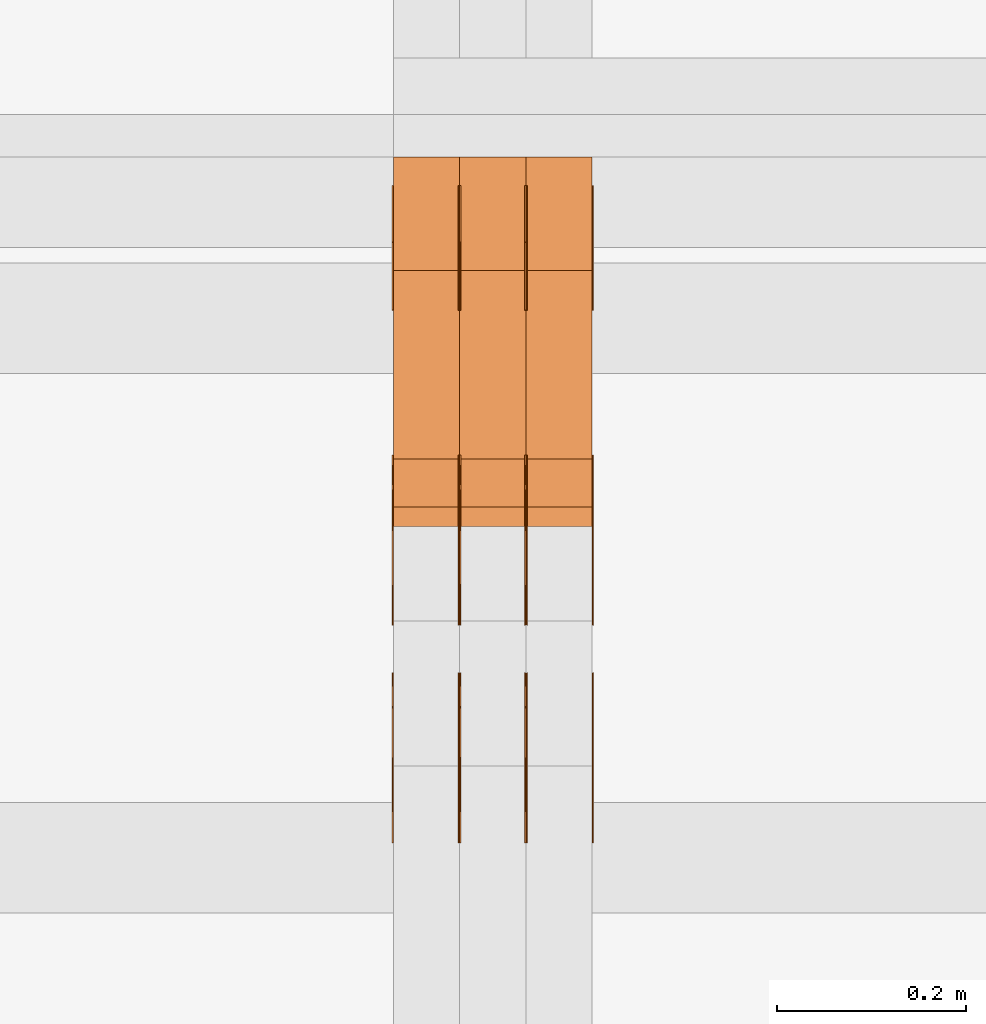
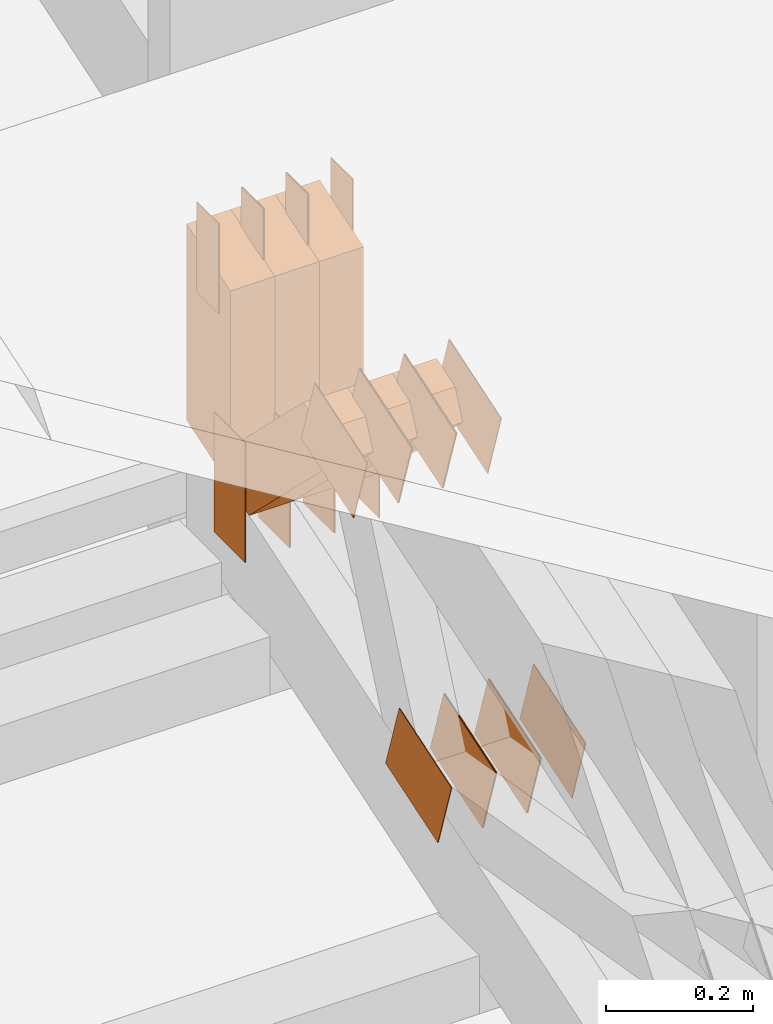
# One storey, part 146 of 385: 30 proxies.
"""IFC2X3 building model written with IfcOpenShell, lengths in millimetres."""

from ifc_helpers import new_model, entity, si_unit, converted_unit, derived_unit, direction, frame, frame_2d, origin, origin_2d_with_axis, place, context, subcontext, project, spatial, polyline, rectangle, outline, extrude, source, transform, mapped, material, type_object, type_shapes, element, save


model = new_model("IFC2X3")

# Units and contexts
model_context = context("Model", 3, precision=0.01, world=origin(), true_north=direction((6.12303176911189e-17, 1.0)))
body_context = subcontext(model_context, "Body", "Model", "MODEL_VIEW")
ifc_project = project(units=[si_unit("LENGTHUNIT", "METRE", prefix="MILLI"), si_unit("AREAUNIT", "SQUARE_METRE"), si_unit("VOLUMEUNIT", "CUBIC_METRE"), converted_unit("PLANEANGLEUNIT", "DEGREE", entity("IfcRatioMeasure", 0.0174532925199433), si_unit("PLANEANGLEUNIT", "RADIAN"), dimensions=[0, 0, 0, 0, 0, 0, 0]), si_unit("MASSUNIT", "GRAM", prefix="KILO"), derived_unit("MASSDENSITYUNIT", [(si_unit("MASSUNIT", "GRAM", prefix="KILO"), 1), (si_unit("LENGTHUNIT", "METRE"), -3)]), si_unit("TIMEUNIT", "SECOND"), si_unit("FREQUENCYUNIT", "HERTZ"), si_unit("THERMODYNAMICTEMPERATUREUNIT", "DEGREE_CELSIUS"), derived_unit("THERMALTRANSMITTANCEUNIT", [(si_unit("MASSUNIT", "GRAM", prefix="KILO"), 1), (si_unit("THERMODYNAMICTEMPERATUREUNIT", "KELVIN"), -1), (si_unit("TIMEUNIT", "SECOND"), -3)]), derived_unit("VOLUMETRICFLOWRATEUNIT", [(si_unit("LENGTHUNIT", "METRE"), 3), (si_unit("TIMEUNIT", "SECOND"), -1)]), si_unit("ELECTRICCURRENTUNIT", "AMPERE"), si_unit("ELECTRICVOLTAGEUNIT", "VOLT"), si_unit("POWERUNIT", "WATT"), si_unit("FORCEUNIT", "NEWTON", prefix="KILO"), si_unit("ILLUMINANCEUNIT", "LUX"), si_unit("LUMINOUSFLUXUNIT", "LUMEN"), si_unit("LUMINOUSINTENSITYUNIT", "CANDELA"), derived_unit("USERDEFINED", [(si_unit("MASSUNIT", "GRAM", prefix="KILO"), -1), (si_unit("LENGTHUNIT", "METRE"), -2), (si_unit("TIMEUNIT", "SECOND"), 3), (si_unit("LUMINOUSFLUXUNIT", "LUMEN"), 1)]), derived_unit("LINEARVELOCITYUNIT", [(si_unit("LENGTHUNIT", "METRE"), 1), (si_unit("TIMEUNIT", "SECOND"), -1)]), si_unit("PRESSUREUNIT", "PASCAL"), derived_unit("USERDEFINED", [(si_unit("LENGTHUNIT", "METRE"), -2), (si_unit("MASSUNIT", "GRAM", prefix="KILO"), 1), (si_unit("TIMEUNIT", "SECOND"), -2)])], contexts=[model_context])

# Site, building, storey
site_placement = place(None, origin())
site = spatial("IfcSite", under=ifc_project, at=site_placement, CompositionType="ELEMENT")
building_placement = place(site_placement, origin())
building = spatial("IfcBuilding", under=site, at=building_placement, CompositionType="ELEMENT")
storey_placement = place(building_placement, origin())
storey = spatial("IfcBuildingStorey", under=building, at=storey_placement, Name="Default", CompositionType="ELEMENT", Elevation=0.0)

# Proxies
ifc_material_1 = material(Name="IfcSurfaceStyle #278004")
building_element_proxy_type_1 = type_object("IfcBuildingElementProxyType", PredefinedType="NOTDEFINED", material=ifc_material_1)
shared_shape_1 = source(origin(), body_context, "Body", "SweptSolid", [
    extrude(rectangle(XDim=200.0, YDim=84.0, at=frame_2d((0.0, -7.105427357601e-15), x_axis=(1.0, 0.0))), frame((100.0, 42.0, 0.0), z_axis=(0.0, 0.0, 1.0), x_axis=(-1.0, 0.0, 0.0)), (0.0, 0.0, 1.0), 1.3),
])
type_shapes(building_element_proxy_type_1, [shared_shape_1])
proxy_1_placement = place(building_placement, frame((21386.3, 13702.0, 3651.4150390625), z_axis=(-1.0, 0.0, 0.0), x_axis=(0.0, 0.0, -1.0)))
element("IfcBuildingElementProxy", 1, at=proxy_1_placement, inside=storey, type_object=building_element_proxy_type_1, material=ifc_material_1, context=body_context, shape_type="MappedRepresentation", body=[
    mapped(shared_shape_1, transform((0.0, 0.0, 0.0), scale=1.0)),
])
ifc_material_2 = material(Name="IfcSurfaceStyle #277947")
building_element_proxy_type_2 = type_object("IfcBuildingElementProxyType", PredefinedType="NOTDEFINED", material=ifc_material_2)
shared_shape_2 = source(origin(), body_context, "Body", "SweptSolid", [
    extrude(rectangle(XDim=200.0, YDim=84.0, at=frame_2d((0.0, -7.105427357601e-15), x_axis=(1.0, 0.0))), frame((100.0, 42.0, 0.0), z_axis=(0.0, 0.0, 1.0), x_axis=(-1.0, 0.0, 0.0)), (0.0, 0.0, 1.0), 1.3),
])
type_shapes(building_element_proxy_type_2, [shared_shape_2])
proxy_2_placement = place(building_placement, frame((21315.0, 13702.0, 3651.4150390625), z_axis=(-1.0, 0.0, 0.0), x_axis=(0.0, 0.0, -1.0)))
element("IfcBuildingElementProxy", 2, at=proxy_2_placement, inside=storey, type_object=building_element_proxy_type_2, material=ifc_material_2, context=body_context, shape_type="MappedRepresentation", body=[
    mapped(shared_shape_2, transform((0.0, 0.0, 0.0), scale=1.0)),
])
ifc_material_3 = material(Name="IfcSurfaceStyle #277890")
building_element_proxy_type_3 = type_object("IfcBuildingElementProxyType", PredefinedType="NOTDEFINED", material=ifc_material_3)
shared_shape_3 = source(origin(), body_context, "Body", "SweptSolid", [
    extrude(rectangle(XDim=200.0, YDim=84.0, at=frame_2d((0.0, -7.105427357601e-15), x_axis=(1.0, 0.0))), frame((100.0, 42.0, 0.0), z_axis=(0.0, 0.0, 1.0), x_axis=(-1.0, 0.0, 0.0)), (0.0, 0.0, 1.0), 1.3),
])
type_shapes(building_element_proxy_type_3, [shared_shape_3])
proxy_3_placement = place(building_placement, frame((21316.3, 13702.0, 3651.4150390625), z_axis=(-1.0, 0.0, 0.0), x_axis=(0.0, 0.0, -1.0)))
element("IfcBuildingElementProxy", 3, at=proxy_3_placement, inside=storey, type_object=building_element_proxy_type_3, material=ifc_material_3, context=body_context, shape_type="MappedRepresentation", body=[
    mapped(shared_shape_3, transform((0.0, 0.0, 0.0), scale=1.0)),
])
ifc_material_4 = material(Name="IfcSurfaceStyle #277833")
building_element_proxy_type_4 = type_object("IfcBuildingElementProxyType", PredefinedType="NOTDEFINED", material=ifc_material_4)
shared_shape_4 = source(origin(), body_context, "Body", "SweptSolid", [
    extrude(rectangle(XDim=200.0, YDim=84.0, at=frame_2d((0.0, -7.105427357601e-15), x_axis=(1.0, 0.0))), frame((100.0, 42.0, 0.0), z_axis=(0.0, 0.0, 1.0), x_axis=(-1.0, 0.0, 0.0)), (0.0, 0.0, 1.0), 1.29999999999998),
])
type_shapes(building_element_proxy_type_4, [shared_shape_4])
proxy_4_placement = place(building_placement, frame((21245.0, 13702.0, 3651.4150390625), z_axis=(-1.0, 0.0, 0.0), x_axis=(0.0, 0.0, -1.0)))
element("IfcBuildingElementProxy", 4, at=proxy_4_placement, inside=storey, type_object=building_element_proxy_type_4, material=ifc_material_4, context=body_context, shape_type="MappedRepresentation", body=[
    mapped(shared_shape_4, transform((0.0, 0.0, 0.0), scale=1.0)),
])
ifc_material_5 = material(Name="IfcSurfaceStyle #277776")
building_element_proxy_type_5 = type_object("IfcBuildingElementProxyType", PredefinedType="NOTDEFINED", material=ifc_material_5)
shared_shape_5 = source(origin(), body_context, "Body", "SweptSolid", [
    extrude(rectangle(XDim=200.0, YDim=84.0, at=frame_2d((0.0, -7.105427357601e-15), x_axis=(1.0, 0.0))), frame((100.0, 42.0, 0.0), z_axis=(0.0, 0.0, 1.0), x_axis=(-1.0, 0.0, 0.0)), (0.0, 0.0, 1.0), 1.29999999999998),
])
type_shapes(building_element_proxy_type_5, [shared_shape_5])
proxy_5_placement = place(building_placement, frame((21246.3, 13702.0, 3651.4150390625), z_axis=(-1.0, 0.0, 0.0), x_axis=(0.0, 0.0, -1.0)))
element("IfcBuildingElementProxy", 5, at=proxy_5_placement, inside=storey, type_object=building_element_proxy_type_5, material=ifc_material_5, context=body_context, shape_type="MappedRepresentation", body=[
    mapped(shared_shape_5, transform((0.0, 0.0, 0.0), scale=1.0)),
])
ifc_material_6 = material(Name="IfcSurfaceStyle #277719")
building_element_proxy_type_6 = type_object("IfcBuildingElementProxyType", PredefinedType="NOTDEFINED", material=ifc_material_6)
shared_shape_6 = source(origin(), body_context, "Body", "SweptSolid", [
    extrude(rectangle(XDim=200.0, YDim=84.0, at=frame_2d((0.0, -7.105427357601e-15), x_axis=(1.0, 0.0))), frame((100.0, 42.0, 0.0), z_axis=(0.0, 0.0, 1.0), x_axis=(-1.0, 0.0, 0.0)), (0.0, 0.0, 1.0), 1.29999999999999),
])
type_shapes(building_element_proxy_type_6, [shared_shape_6])
proxy_6_placement = place(building_placement, frame((21175.0, 13702.0, 3651.4150390625), z_axis=(-1.0, 0.0, 0.0), x_axis=(0.0, 0.0, -1.0)))
element("IfcBuildingElementProxy", 6, at=proxy_6_placement, inside=storey, type_object=building_element_proxy_type_6, material=ifc_material_6, context=body_context, shape_type="MappedRepresentation", body=[
    mapped(shared_shape_6, transform((0.0, 0.0, 0.0), scale=1.0)),
])
ifc_material_7 = material(Name="IfcSurfaceStyle #277662")
building_element_proxy_type_7 = type_object("IfcBuildingElementProxyType", PredefinedType="NOTDEFINED", material=ifc_material_7)
shared_shape_7 = source(origin(), body_context, "Body", "SweptSolid", [
    extrude(outline(polyline([(-75.0003398116828, -59.9998507501386), (75.0003249421766, -59.9998507501386), (75.0003398116837, 59.9998507501387), (-75.0003249421775, 59.9998507501387), (-75.0003398116828, -59.9998507501386)])), frame((75.0003398116837, 60.0000773549637, 0.0), z_axis=(0.0, 0.0, 1.0), x_axis=(-1.0, 0.0, 0.0)), (0.0, 0.0, 1.0), 1.3),
])
type_shapes(building_element_proxy_type_7, [shared_shape_7])
proxy_7_placement = place(building_placement, frame((21386.3, 13054.73046875, 3417.8388671875), z_axis=(-1.0, 0.0, 0.0), x_axis=(0.0, 0.951056516295124, 0.309016994375039)))
element("IfcBuildingElementProxy", 7, at=proxy_7_placement, inside=storey, type_object=building_element_proxy_type_7, material=ifc_material_7, context=body_context, shape_type="MappedRepresentation", body=[
    mapped(shared_shape_7, transform((0.0, 0.0, 0.0), scale=1.0)),
])
ifc_material_8 = material(Name="IfcSurfaceStyle #277605")
building_element_proxy_type_8 = type_object("IfcBuildingElementProxyType", PredefinedType="NOTDEFINED", material=ifc_material_8)
shared_shape_8 = source(origin(), body_context, "Body", "SweptSolid", [
    extrude(outline(polyline([(-75.0003398116828, -59.9998507501386), (75.0003249421766, -59.9998507501386), (75.0003398116837, 59.9998507501387), (-75.0003249421775, 59.9998507501387), (-75.0003398116828, -59.9998507501386)])), frame((75.0003398116837, 60.0000773549637, 0.0), z_axis=(0.0, 0.0, 1.0), x_axis=(-1.0, 0.0, 0.0)), (0.0, 0.0, 1.0), 1.3),
])
type_shapes(building_element_proxy_type_8, [shared_shape_8])
proxy_8_placement = place(building_placement, frame((21315.0, 13054.73046875, 3417.8388671875), z_axis=(-1.0, 0.0, 0.0), x_axis=(0.0, 0.951056516295124, 0.309016994375039)))
element("IfcBuildingElementProxy", 8, at=proxy_8_placement, inside=storey, type_object=building_element_proxy_type_8, material=ifc_material_8, context=body_context, shape_type="MappedRepresentation", body=[
    mapped(shared_shape_8, transform((0.0, 0.0, 0.0), scale=1.0)),
])
ifc_material_9 = material(Name="IfcSurfaceStyle #277548")
building_element_proxy_type_9 = type_object("IfcBuildingElementProxyType", PredefinedType="NOTDEFINED", material=ifc_material_9)
shared_shape_9 = source(origin(), body_context, "Body", "SweptSolid", [
    extrude(outline(polyline([(-75.0003398116828, -59.9998507501386), (75.0003249421766, -59.9998507501386), (75.0003398116837, 59.9998507501387), (-75.0003249421775, 59.9998507501387), (-75.0003398116828, -59.9998507501386)])), frame((75.0003398116837, 60.0000773549637, 0.0), z_axis=(0.0, 0.0, 1.0), x_axis=(-1.0, 0.0, 0.0)), (0.0, 0.0, 1.0), 1.3),
])
type_shapes(building_element_proxy_type_9, [shared_shape_9])
proxy_9_placement = place(building_placement, frame((21316.3, 13054.73046875, 3417.8388671875), z_axis=(-1.0, 0.0, 0.0), x_axis=(0.0, 0.951056516295124, 0.309016994375039)))
element("IfcBuildingElementProxy", 9, at=proxy_9_placement, inside=storey, type_object=building_element_proxy_type_9, material=ifc_material_9, context=body_context, shape_type="MappedRepresentation", body=[
    mapped(shared_shape_9, transform((0.0, 0.0, 0.0), scale=1.0)),
])
ifc_material_10 = material(Name="IfcSurfaceStyle #277491")
building_element_proxy_type_10 = type_object("IfcBuildingElementProxyType", PredefinedType="NOTDEFINED", material=ifc_material_10)
shared_shape_10 = source(origin(), body_context, "Body", "SweptSolid", [
    extrude(outline(polyline([(-75.0003398116828, -59.9998507501386), (75.0003249421766, -59.9998507501386), (75.0003398116837, 59.9998507501387), (-75.0003249421775, 59.9998507501387), (-75.0003398116828, -59.9998507501386)])), frame((75.0003398116837, 60.0000773549637, 0.0), z_axis=(0.0, 0.0, 1.0), x_axis=(-1.0, 0.0, 0.0)), (0.0, 0.0, 1.0), 1.29999999999999),
])
type_shapes(building_element_proxy_type_10, [shared_shape_10])
proxy_10_placement = place(building_placement, frame((21245.0, 13054.73046875, 3417.8388671875), z_axis=(-1.0, 0.0, 0.0), x_axis=(0.0, 0.951056516295124, 0.309016994375039)))
element("IfcBuildingElementProxy", 10, at=proxy_10_placement, inside=storey, type_object=building_element_proxy_type_10, material=ifc_material_10, context=body_context, shape_type="MappedRepresentation", body=[
    mapped(shared_shape_10, transform((0.0, 0.0, 0.0), scale=1.0)),
])
ifc_material_11 = material(Name="IfcSurfaceStyle #277434")
building_element_proxy_type_11 = type_object("IfcBuildingElementProxyType", PredefinedType="NOTDEFINED", material=ifc_material_11)
shared_shape_11 = source(origin(), body_context, "Body", "SweptSolid", [
    extrude(outline(polyline([(-75.0003398116828, -59.9998507501386), (75.0003249421766, -59.9998507501386), (75.0003398116837, 59.9998507501387), (-75.0003249421775, 59.9998507501387), (-75.0003398116828, -59.9998507501386)])), frame((75.0003398116837, 60.0000773549637, 0.0), z_axis=(0.0, 0.0, 1.0), x_axis=(-1.0, 0.0, 0.0)), (0.0, 0.0, 1.0), 1.29999999999999),
])
type_shapes(building_element_proxy_type_11, [shared_shape_11])
proxy_11_placement = place(building_placement, frame((21246.3, 13054.73046875, 3417.8388671875), z_axis=(-1.0, 0.0, 0.0), x_axis=(0.0, 0.951056516295124, 0.309016994375039)))
element("IfcBuildingElementProxy", 11, at=proxy_11_placement, inside=storey, type_object=building_element_proxy_type_11, material=ifc_material_11, context=body_context, shape_type="MappedRepresentation", body=[
    mapped(shared_shape_11, transform((0.0, 0.0, 0.0), scale=1.0)),
])
ifc_material_12 = material(Name="IfcSurfaceStyle #277377")
building_element_proxy_type_12 = type_object("IfcBuildingElementProxyType", PredefinedType="NOTDEFINED", material=ifc_material_12)
shared_shape_12 = source(origin(), body_context, "Body", "SweptSolid", [
    extrude(outline(polyline([(-75.0003398116828, -59.9998507501386), (75.0003249421766, -59.9998507501386), (75.0003398116837, 59.9998507501387), (-75.0003249421775, 59.9998507501387), (-75.0003398116828, -59.9998507501386)])), frame((75.0003398116837, 60.0000773549637, 0.0), z_axis=(0.0, 0.0, 1.0), x_axis=(-1.0, 0.0, 0.0)), (0.0, 0.0, 1.0), 1.29999999999999),
])
type_shapes(building_element_proxy_type_12, [shared_shape_12])
proxy_12_placement = place(building_placement, frame((21175.0, 13054.73046875, 3417.8388671875), z_axis=(-1.0, 0.0, 0.0), x_axis=(0.0, 0.951056516295124, 0.309016994375039)))
element("IfcBuildingElementProxy", 12, at=proxy_12_placement, inside=storey, type_object=building_element_proxy_type_12, material=ifc_material_12, context=body_context, shape_type="MappedRepresentation", body=[
    mapped(shared_shape_12, transform((0.0, 0.0, 0.0), scale=1.0)),
])
ifc_material_13 = material(Name="IfcSurfaceStyle #269796")
building_element_proxy_type_13 = type_object("IfcBuildingElementProxyType", PredefinedType="NOTDEFINED", material=ifc_material_13)
shared_shape_13 = source(origin(), body_context, "Body", "SweptSolid", [
    extrude(outline(polyline([(-74.999875428623, -60.0000016373506), (74.9998605591059, -60.0000016373506), (74.9998754286239, 60.0000016373506), (-74.9998605591068, 60.0000016373506), (-74.999875428623, -60.0000016373506)])), frame((75.0002691827262, 60.0000190504561, 0.0), z_axis=(0.0, 0.0, 1.0), x_axis=(-1.0, 0.0, 0.0)), (0.0, 0.0, 1.0), 1.3),
])
type_shapes(building_element_proxy_type_13, [shared_shape_13])
proxy_13_placement = place(building_placement, frame((21386.3, 13285.0865109705, 3819.37496637467), z_axis=(-1.0, 0.0, 0.0), x_axis=(0.0, 0.951056516295154, 0.309016994374948)))
element("IfcBuildingElementProxy", 13, at=proxy_13_placement, inside=storey, type_object=building_element_proxy_type_13, material=ifc_material_13, context=body_context, shape_type="MappedRepresentation", body=[
    mapped(shared_shape_13, transform((0.0, 0.0, 0.0), scale=1.0)),
])
ifc_material_14 = material(Name="IfcSurfaceStyle #269739")
building_element_proxy_type_14 = type_object("IfcBuildingElementProxyType", PredefinedType="NOTDEFINED", material=ifc_material_14)
shared_shape_14 = source(origin(), body_context, "Body", "SweptSolid", [
    extrude(outline(polyline([(-74.999875428623, -60.0000016373506), (74.9998605591059, -60.0000016373506), (74.9998754286239, 60.0000016373506), (-74.9998605591068, 60.0000016373506), (-74.999875428623, -60.0000016373506)])), frame((75.0002691827262, 60.0000190504561, 0.0), z_axis=(0.0, 0.0, 1.0), x_axis=(-1.0, 0.0, 0.0)), (0.0, 0.0, 1.0), 1.3),
])
type_shapes(building_element_proxy_type_14, [shared_shape_14])
proxy_14_placement = place(building_placement, frame((21315.0, 13285.0865109705, 3819.37496637467), z_axis=(-1.0, 0.0, 0.0), x_axis=(0.0, 0.951056516295154, 0.309016994374948)))
element("IfcBuildingElementProxy", 14, at=proxy_14_placement, inside=storey, type_object=building_element_proxy_type_14, material=ifc_material_14, context=body_context, shape_type="MappedRepresentation", body=[
    mapped(shared_shape_14, transform((0.0, 0.0, 0.0), scale=1.0)),
])
ifc_material_15 = material(Name="IfcSurfaceStyle #269682")
building_element_proxy_type_15 = type_object("IfcBuildingElementProxyType", PredefinedType="NOTDEFINED", material=ifc_material_15)
shared_shape_15 = source(origin(), body_context, "Body", "SweptSolid", [
    extrude(outline(polyline([(-74.999875428623, -60.0000016373506), (74.9998605591059, -60.0000016373506), (74.9998754286239, 60.0000016373506), (-74.9998605591068, 60.0000016373506), (-74.999875428623, -60.0000016373506)])), frame((75.0002691827262, 60.0000190504561, 0.0), z_axis=(0.0, 0.0, 1.0), x_axis=(-1.0, 0.0, 0.0)), (0.0, 0.0, 1.0), 1.3),
])
type_shapes(building_element_proxy_type_15, [shared_shape_15])
proxy_15_placement = place(building_placement, frame((21316.3, 13285.0865109705, 3819.37496637467), z_axis=(-1.0, 0.0, 0.0), x_axis=(0.0, 0.951056516295154, 0.309016994374948)))
element("IfcBuildingElementProxy", 15, at=proxy_15_placement, inside=storey, type_object=building_element_proxy_type_15, material=ifc_material_15, context=body_context, shape_type="MappedRepresentation", body=[
    mapped(shared_shape_15, transform((0.0, 0.0, 0.0), scale=1.0)),
])
ifc_material_16 = material(Name="IfcSurfaceStyle #269625")
building_element_proxy_type_16 = type_object("IfcBuildingElementProxyType", PredefinedType="NOTDEFINED", material=ifc_material_16)
shared_shape_16 = source(origin(), body_context, "Body", "SweptSolid", [
    extrude(outline(polyline([(-74.999875428623, -60.0000016373506), (74.9998605591059, -60.0000016373506), (74.9998754286239, 60.0000016373506), (-74.9998605591068, 60.0000016373506), (-74.999875428623, -60.0000016373506)])), frame((75.0002691827262, 60.0000190504561, 0.0), z_axis=(0.0, 0.0, 1.0), x_axis=(-1.0, 0.0, 0.0)), (0.0, 0.0, 1.0), 1.29999999999999),
])
type_shapes(building_element_proxy_type_16, [shared_shape_16])
proxy_16_placement = place(building_placement, frame((21245.0, 13285.0865109705, 3819.37496637467), z_axis=(-1.0, 0.0, 0.0), x_axis=(0.0, 0.951056516295154, 0.309016994374948)))
element("IfcBuildingElementProxy", 16, at=proxy_16_placement, inside=storey, type_object=building_element_proxy_type_16, material=ifc_material_16, context=body_context, shape_type="MappedRepresentation", body=[
    mapped(shared_shape_16, transform((0.0, 0.0, 0.0), scale=1.0)),
])
ifc_material_17 = material(Name="IfcSurfaceStyle #269568")
building_element_proxy_type_17 = type_object("IfcBuildingElementProxyType", PredefinedType="NOTDEFINED", material=ifc_material_17)
shared_shape_17 = source(origin(), body_context, "Body", "SweptSolid", [
    extrude(outline(polyline([(-74.999875428623, -60.0000016373506), (74.9998605591059, -60.0000016373506), (74.9998754286239, 60.0000016373506), (-74.9998605591068, 60.0000016373506), (-74.999875428623, -60.0000016373506)])), frame((75.0002691827262, 60.0000190504561, 0.0), z_axis=(0.0, 0.0, 1.0), x_axis=(-1.0, 0.0, 0.0)), (0.0, 0.0, 1.0), 1.29999999999999),
])
type_shapes(building_element_proxy_type_17, [shared_shape_17])
proxy_17_placement = place(building_placement, frame((21246.3, 13285.0865109705, 3819.37496637467), z_axis=(-1.0, 0.0, 0.0), x_axis=(0.0, 0.951056516295154, 0.309016994374948)))
element("IfcBuildingElementProxy", 17, at=proxy_17_placement, inside=storey, type_object=building_element_proxy_type_17, material=ifc_material_17, context=body_context, shape_type="MappedRepresentation", body=[
    mapped(shared_shape_17, transform((0.0, 0.0, 0.0), scale=1.0)),
])
ifc_material_18 = material(Name="IfcSurfaceStyle #269511")
building_element_proxy_type_18 = type_object("IfcBuildingElementProxyType", PredefinedType="NOTDEFINED", material=ifc_material_18)
shared_shape_18 = source(origin(), body_context, "Body", "SweptSolid", [
    extrude(outline(polyline([(-74.999875428623, -60.0000016373506), (74.9998605591059, -60.0000016373506), (74.9998754286239, 60.0000016373506), (-74.9998605591068, 60.0000016373506), (-74.999875428623, -60.0000016373506)])), frame((75.0002691827262, 60.0000190504561, 0.0), z_axis=(0.0, 0.0, 1.0), x_axis=(-1.0, 0.0, 0.0)), (0.0, 0.0, 1.0), 1.29999999999999),
])
type_shapes(building_element_proxy_type_18, [shared_shape_18])
proxy_18_placement = place(building_placement, frame((21175.0, 13285.0865109705, 3819.37496637467), z_axis=(-1.0, 0.0, 0.0), x_axis=(0.0, 0.951056516295154, 0.309016994374948)))
element("IfcBuildingElementProxy", 18, at=proxy_18_placement, inside=storey, type_object=building_element_proxy_type_18, material=ifc_material_18, context=body_context, shape_type="MappedRepresentation", body=[
    mapped(shared_shape_18, transform((0.0, 0.0, 0.0), scale=1.0)),
])
ifc_material_19 = material(Name="IfcSurfaceStyle #269112")
building_element_proxy_type_19 = type_object("IfcBuildingElementProxyType", PredefinedType="NOTDEFINED", material=ifc_material_19)
shared_shape_19 = source(origin(), body_context, "Body", "SweptSolid", [
    extrude(rectangle(XDim=150.0, YDim=60.0, at=origin_2d_with_axis()), frame((75.0000705696166, 30.0, 0.0), z_axis=(0.0, 0.0, 1.0), x_axis=(-1.0, 0.0, 0.0)), (0.0, 0.0, 1.0), 1.3),
])
type_shapes(building_element_proxy_type_19, [shared_shape_19])
proxy_19_placement = place(building_placement, frame((21386.3, 13750.0, 3972.59919166337), z_axis=(-1.0, 0.0, 0.0), x_axis=(0.0, 0.0, -1.0)))
element("IfcBuildingElementProxy", 19, at=proxy_19_placement, inside=storey, type_object=building_element_proxy_type_19, material=ifc_material_19, context=body_context, shape_type="MappedRepresentation", body=[
    mapped(shared_shape_19, transform((0.0, 0.0, 0.0), scale=1.0)),
])
ifc_material_20 = material(Name="IfcSurfaceStyle #269055")
building_element_proxy_type_20 = type_object("IfcBuildingElementProxyType", PredefinedType="NOTDEFINED", material=ifc_material_20)
shared_shape_20 = source(origin(), body_context, "Body", "SweptSolid", [
    extrude(rectangle(XDim=150.0, YDim=60.0, at=origin_2d_with_axis()), frame((75.0000705696166, 30.0, 0.0), z_axis=(0.0, 0.0, 1.0), x_axis=(-1.0, 0.0, 0.0)), (0.0, 0.0, 1.0), 1.3),
])
type_shapes(building_element_proxy_type_20, [shared_shape_20])
proxy_20_placement = place(building_placement, frame((21315.0, 13750.0, 3972.59919166337), z_axis=(-1.0, 0.0, 0.0), x_axis=(0.0, 0.0, -1.0)))
element("IfcBuildingElementProxy", 20, at=proxy_20_placement, inside=storey, type_object=building_element_proxy_type_20, material=ifc_material_20, context=body_context, shape_type="MappedRepresentation", body=[
    mapped(shared_shape_20, transform((0.0, 0.0, 0.0), scale=1.0)),
])
ifc_material_21 = material(Name="IfcSurfaceStyle #268998")
building_element_proxy_type_21 = type_object("IfcBuildingElementProxyType", PredefinedType="NOTDEFINED", material=ifc_material_21)
shared_shape_21 = source(origin(), body_context, "Body", "SweptSolid", [
    extrude(rectangle(XDim=150.0, YDim=60.0, at=origin_2d_with_axis()), frame((75.0000705696166, 30.0, 0.0), z_axis=(0.0, 0.0, 1.0), x_axis=(-1.0, 0.0, 0.0)), (0.0, 0.0, 1.0), 1.3),
])
type_shapes(building_element_proxy_type_21, [shared_shape_21])
proxy_21_placement = place(building_placement, frame((21316.3, 13750.0, 3972.59919166337), z_axis=(-1.0, 0.0, 0.0), x_axis=(0.0, 0.0, -1.0)))
element("IfcBuildingElementProxy", 21, at=proxy_21_placement, inside=storey, type_object=building_element_proxy_type_21, material=ifc_material_21, context=body_context, shape_type="MappedRepresentation", body=[
    mapped(shared_shape_21, transform((0.0, 0.0, 0.0), scale=1.0)),
])
ifc_material_22 = material(Name="IfcSurfaceStyle #268941")
building_element_proxy_type_22 = type_object("IfcBuildingElementProxyType", PredefinedType="NOTDEFINED", material=ifc_material_22)
shared_shape_22 = source(origin(), body_context, "Body", "SweptSolid", [
    extrude(rectangle(XDim=150.0, YDim=60.0, at=origin_2d_with_axis()), frame((75.0000705696166, 30.0, 0.0), z_axis=(0.0, 0.0, 1.0), x_axis=(-1.0, 0.0, 0.0)), (0.0, 0.0, 1.0), 1.29999999999999),
])
type_shapes(building_element_proxy_type_22, [shared_shape_22])
proxy_22_placement = place(building_placement, frame((21245.0, 13750.0, 3972.59919166337), z_axis=(-1.0, 0.0, 0.0), x_axis=(0.0, 0.0, -1.0)))
element("IfcBuildingElementProxy", 22, at=proxy_22_placement, inside=storey, type_object=building_element_proxy_type_22, material=ifc_material_22, context=body_context, shape_type="MappedRepresentation", body=[
    mapped(shared_shape_22, transform((0.0, 0.0, 0.0), scale=1.0)),
])
ifc_material_23 = material(Name="IfcSurfaceStyle #268884")
building_element_proxy_type_23 = type_object("IfcBuildingElementProxyType", PredefinedType="NOTDEFINED", material=ifc_material_23)
shared_shape_23 = source(origin(), body_context, "Body", "SweptSolid", [
    extrude(rectangle(XDim=150.0, YDim=60.0, at=origin_2d_with_axis()), frame((75.0000705696166, 30.0, 0.0), z_axis=(0.0, 0.0, 1.0), x_axis=(-1.0, 0.0, 0.0)), (0.0, 0.0, 1.0), 1.29999999999999),
])
type_shapes(building_element_proxy_type_23, [shared_shape_23])
proxy_23_placement = place(building_placement, frame((21246.3, 13750.0, 3972.59919166337), z_axis=(-1.0, 0.0, 0.0), x_axis=(0.0, 0.0, -1.0)))
element("IfcBuildingElementProxy", 23, at=proxy_23_placement, inside=storey, type_object=building_element_proxy_type_23, material=ifc_material_23, context=body_context, shape_type="MappedRepresentation", body=[
    mapped(shared_shape_23, transform((0.0, 0.0, 0.0), scale=1.0)),
])
ifc_material_24 = material(Name="IfcSurfaceStyle #268827")
building_element_proxy_type_24 = type_object("IfcBuildingElementProxyType", PredefinedType="NOTDEFINED", material=ifc_material_24)
shared_shape_24 = source(origin(), body_context, "Body", "SweptSolid", [
    extrude(rectangle(XDim=150.0, YDim=60.0, at=origin_2d_with_axis()), frame((75.0000705696166, 30.0, 0.0), z_axis=(0.0, 0.0, 1.0), x_axis=(-1.0, 0.0, 0.0)), (0.0, 0.0, 1.0), 1.29999999999999),
])
type_shapes(building_element_proxy_type_24, [shared_shape_24])
proxy_24_placement = place(building_placement, frame((21175.0, 13750.0, 3972.59919166337), z_axis=(-1.0, 0.0, 0.0), x_axis=(0.0, 0.0, -1.0)))
element("IfcBuildingElementProxy", 24, at=proxy_24_placement, inside=storey, type_object=building_element_proxy_type_24, material=ifc_material_24, context=body_context, shape_type="MappedRepresentation", body=[
    mapped(shared_shape_24, transform((0.0, 0.0, 0.0), scale=1.0)),
])
ifc_material_25 = material(Name="IfcSurfaceStyle #259626")
building_element_proxy_type_25 = type_object("IfcBuildingElementProxyType", Name="T1-W49 259624", PredefinedType="NOTDEFINED", material=ifc_material_25)
shared_shape_25 = source(origin(), body_context, "Body", "SweptSolid", [
    extrude(outline(polyline([(-155.175867306415, -47.4997478409253), (152.310664695054, -47.4997478409253), (170.496756790954, -6.14570120142345e-05), (145.70957993751, 47.4998092979374), (-133.37808995724, 47.4998092979373), (-179.963044159863, -6.14570120298391e-05), (-155.175867306415, -47.4997478409253)])), frame((170.496756790954, 47.5001152140455, 0.0), z_axis=(0.0, 0.0, 1.0), x_axis=(-1.0, 0.0, 0.0)), (0.0, 0.0, 1.0), 70.0),
])
type_shapes(building_element_proxy_type_25, [shared_shape_25])
proxy_25_placement = place(building_placement, frame((21385.0, 13443.048524104, 3830.71841973934), z_axis=(-1.0, 0.0, 0.0), x_axis=(0.0, 0.713950095632063, -0.700196587357413)))
element("IfcBuildingElementProxy", 25, at=proxy_25_placement, inside=storey, type_object=building_element_proxy_type_25, material=ifc_material_25, Name="T1-W49", context=body_context, shape_type="MappedRepresentation", body=[
    mapped(shared_shape_25, transform((0.0, 0.0, 0.0), scale=1.0)),
])
ifc_material_26 = material(Name="IfcSurfaceStyle #259551")
building_element_proxy_type_26 = type_object("IfcBuildingElementProxyType", Name="T1-W49 259549", PredefinedType="NOTDEFINED", material=ifc_material_26)
shared_shape_26 = source(origin(), body_context, "Body", "SweptSolid", [
    extrude(outline(polyline([(-155.175867306415, -47.4997478409253), (152.310664695054, -47.4997478409253), (170.496756790954, -6.14570120142345e-05), (145.70957993751, 47.4998092979374), (-133.37808995724, 47.4998092979373), (-179.963044159863, -6.14570120298391e-05), (-155.175867306415, -47.4997478409253)])), frame((170.496756790954, 47.5001152140455, 0.0), z_axis=(0.0, 0.0, 1.0), x_axis=(-1.0, 0.0, 0.0)), (0.0, 0.0, 1.0), 70.0),
])
type_shapes(building_element_proxy_type_26, [shared_shape_26])
proxy_26_placement = place(building_placement, frame((21315.0, 13443.048524104, 3830.71841973934), z_axis=(-1.0, 0.0, 0.0), x_axis=(0.0, 0.713950095632063, -0.700196587357413)))
element("IfcBuildingElementProxy", 26, at=proxy_26_placement, inside=storey, type_object=building_element_proxy_type_26, material=ifc_material_26, Name="T1-W49", context=body_context, shape_type="MappedRepresentation", body=[
    mapped(shared_shape_26, transform((0.0, 0.0, 0.0), scale=1.0)),
])
ifc_material_27 = material(Name="IfcSurfaceStyle #259476")
building_element_proxy_type_27 = type_object("IfcBuildingElementProxyType", Name="T1-W49 259474", PredefinedType="NOTDEFINED", material=ifc_material_27)
shared_shape_27 = source(origin(), body_context, "Body", "SweptSolid", [
    extrude(outline(polyline([(-155.175867306415, -47.4997478409253), (152.310664695054, -47.4997478409253), (170.496756790954, -6.14570120142345e-05), (145.70957993751, 47.4998092979374), (-133.37808995724, 47.4998092979373), (-179.963044159863, -6.14570120298391e-05), (-155.175867306415, -47.4997478409253)])), frame((170.496756790954, 47.5001152140455, 0.0), z_axis=(0.0, 0.0, 1.0), x_axis=(-1.0, 0.0, 0.0)), (0.0, 0.0, 1.0), 70.0),
])
type_shapes(building_element_proxy_type_27, [shared_shape_27])
proxy_27_placement = place(building_placement, frame((21245.0, 13443.048524104, 3830.71841973934), z_axis=(-1.0, 0.0, 0.0), x_axis=(0.0, 0.713950095632063, -0.700196587357413)))
element("IfcBuildingElementProxy", 27, at=proxy_27_placement, inside=storey, type_object=building_element_proxy_type_27, material=ifc_material_27, Name="T1-W49", context=body_context, shape_type="MappedRepresentation", body=[
    mapped(shared_shape_27, transform((0.0, 0.0, 0.0), scale=1.0)),
])
ifc_material_28 = material(Name="IfcSurfaceStyle #259176")
building_element_proxy_type_28 = type_object("IfcBuildingElementProxyType", Name="T1-W1 259174", PredefinedType="NOTDEFINED", material=ifc_material_28)
shared_shape_28 = source(origin(), body_context, "Body", "SweptSolid", [
    extrude(outline(polyline([(-182.839782714844, -60.0), (143.849426269531, -60.0), (182.839660644531, 60.0), (-143.849304199219, 60.0), (-182.839782714844, -60.0)])), frame((182.839674685549, 60.0, 0.0), z_axis=(0.0, 0.0, 1.0), x_axis=(-1.0, 0.0, 0.0)), (0.0, 0.0, 1.0), 70.0),
])
type_shapes(building_element_proxy_type_28, [shared_shape_28])
proxy_28_placement = place(building_placement, frame((21385.0, 13660.0, 3551.41502502148), z_axis=(-1.0, 0.0, 0.0), x_axis=(0.0, 0.0, 1.0)))
element("IfcBuildingElementProxy", 28, at=proxy_28_placement, inside=storey, type_object=building_element_proxy_type_28, material=ifc_material_28, Name="T1-W1", context=body_context, shape_type="MappedRepresentation", body=[
    mapped(shared_shape_28, transform((0.0, 0.0, 0.0), scale=1.0)),
])
ifc_material_29 = material(Name="IfcSurfaceStyle #259119")
building_element_proxy_type_29 = type_object("IfcBuildingElementProxyType", Name="T1-W1 259117", PredefinedType="NOTDEFINED", material=ifc_material_29)
shared_shape_29 = source(origin(), body_context, "Body", "SweptSolid", [
    extrude(outline(polyline([(-182.839782714844, -60.0), (143.849426269531, -60.0), (182.839660644531, 60.0), (-143.849304199219, 60.0), (-182.839782714844, -60.0)])), frame((182.839674685549, 60.0, 0.0), z_axis=(0.0, 0.0, 1.0), x_axis=(-1.0, 0.0, 0.0)), (0.0, 0.0, 1.0), 70.0),
])
type_shapes(building_element_proxy_type_29, [shared_shape_29])
proxy_29_placement = place(building_placement, frame((21315.0, 13660.0, 3551.41502502148), z_axis=(-1.0, 0.0, 0.0), x_axis=(0.0, 0.0, 1.0)))
element("IfcBuildingElementProxy", 29, at=proxy_29_placement, inside=storey, type_object=building_element_proxy_type_29, material=ifc_material_29, Name="T1-W1", context=body_context, shape_type="MappedRepresentation", body=[
    mapped(shared_shape_29, transform((0.0, 0.0, 0.0), scale=1.0)),
])
ifc_material_30 = material(Name="IfcSurfaceStyle #259062")
building_element_proxy_type_30 = type_object("IfcBuildingElementProxyType", Name="T1-W1 259060", PredefinedType="NOTDEFINED", material=ifc_material_30)
shared_shape_30 = source(origin(), body_context, "Body", "SweptSolid", [
    extrude(outline(polyline([(-182.839782714844, -60.0), (143.849426269531, -60.0), (182.839660644531, 60.0), (-143.849304199219, 60.0), (-182.839782714844, -60.0)])), frame((182.839674685549, 60.0, 0.0), z_axis=(0.0, 0.0, 1.0), x_axis=(-1.0, 0.0, 0.0)), (0.0, 0.0, 1.0), 70.0),
])
type_shapes(building_element_proxy_type_30, [shared_shape_30])
proxy_30_placement = place(building_placement, frame((21245.0, 13660.0, 3551.41502502148), z_axis=(-1.0, 0.0, 0.0), x_axis=(0.0, 0.0, 1.0)))
element("IfcBuildingElementProxy", 30, at=proxy_30_placement, inside=storey, type_object=building_element_proxy_type_30, material=ifc_material_30, Name="T1-W1", context=body_context, shape_type="MappedRepresentation", body=[
    mapped(shared_shape_30, transform((0.0, 0.0, 0.0), scale=1.0)),
])

save(model, "model.ifc")
